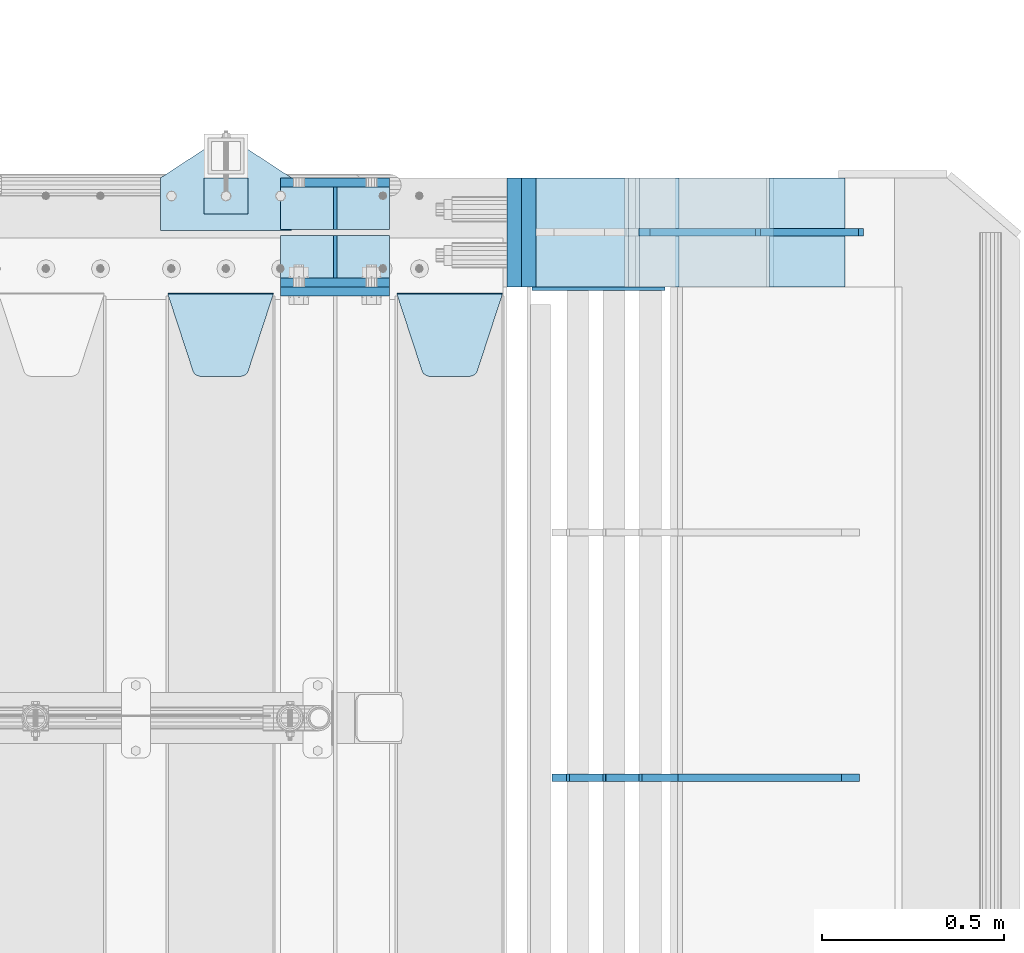
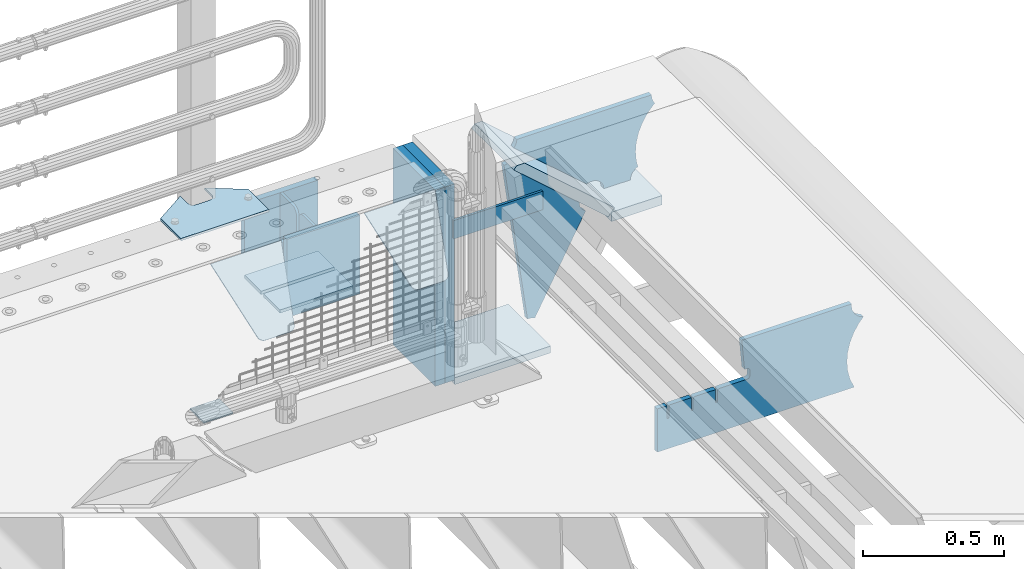
# One storey, part 231 of 247: 20 plates.
"""IFC2X3 building model written with IfcOpenShell, lengths in millimetres."""

from ifc_helpers import new_model, si_unit, frame, origin_with_axes, place, context, subcontext, project, spatial, faceted_brep, material, type_object, element, save


model = new_model("IFC2X3")

# Units and contexts
model_context = context("Model", 3, precision=1e-05, world=origin_with_axes())
body_context = subcontext(model_context, "Body", "Model", "MODEL_VIEW")
ifc_project = project(units=[si_unit("LENGTHUNIT", "METRE", prefix="MILLI"), si_unit("AREAUNIT", "SQUARE_METRE"), si_unit("VOLUMEUNIT", "CUBIC_METRE"), si_unit("MASSUNIT", "GRAM", prefix="KILO"), si_unit("TIMEUNIT", "SECOND"), si_unit("PLANEANGLEUNIT", "RADIAN"), si_unit("SOLIDANGLEUNIT", "STERADIAN"), si_unit("THERMODYNAMICTEMPERATUREUNIT", "DEGREE_CELSIUS"), si_unit("LUMINOUSINTENSITYUNIT", "LUMEN")], contexts=[model_context])

# Site, building, storey
site_placement = place(None, origin_with_axes())
site = spatial("IfcSite", under=ifc_project, at=site_placement, CompositionType="ELEMENT")
building_placement = place(site_placement, origin_with_axes())
building = spatial("IfcBuilding", under=site, at=building_placement, Name="Standard", CompositionType="ELEMENT")
storey_placement = place(building_placement, origin_with_axes())
storey = spatial("IfcBuildingStorey", under=building, at=storey_placement, Name="Undefined", CompositionType="ELEMENT", Elevation=0.0)

# Plates
ifc_material_1 = material(Name="STEEL/S355N")
plate_type_1 = type_object("IfcPlateType", PredefinedType="NOTDEFINED")
for number, where, z_axis, x_axis in (
    (1, (16195.0, 9137.49999999999, -339.999999999993), (0.0, 0.0, 1.0), (1.0, 0.0, 0.0)),
    (2, (16195.0, 8862.49999999999, -339.999999999993), (0.0, 0.0, 1.0), (1.0, 0.0, 0.0)),
):
    element("IfcPlate", number, at=place(storey_placement, frame(where, z_axis=z_axis, x_axis=x_axis)), inside=storey, type_object=plate_type_1, material=ifc_material_1, context=body_context, shape_type="Brep", body=[
        faceted_brep([(0.0, -12.5, 0.0), (0.0, -12.5, 310.0), (0.0, 12.5, 310.0), (0.0, 12.5, 0.0), (300.0, -12.5, 310.0), (300.0, 12.5, 310.0), (300.0, -12.5, 0.0), (300.0, 12.5, 0.0)], [[[0, 1, 2, 3]], [[1, 4, 5, 2]], [[4, 6, 7, 5]], [[6, 0, 3, 7]], [[5, 7, 3, 2]], [[6, 4, 1, 0]]]),
    ])
plate_1_placement = place(storey_placement, frame((16195.0, 8837.5, -340.000000000044), z_axis=(0.0, 0.0, 1.0), x_axis=(1.0, 0.0, 0.0)))
element("IfcPlate", 3, at=plate_1_placement, inside=storey, type_object=plate_type_1, material=ifc_material_1, context=body_context, shape_type="Brep", body=[
    faceted_brep([(0.0, -12.5, 0.0), (0.0, -12.5, 340.0), (0.0, 12.5, 340.0), (0.0, 12.5, 0.0), (300.0, -12.5, 340.0), (300.0, 12.5, 340.0), (300.0, -12.5, 0.0), (300.0, 12.5, 0.0)], [[[0, 1, 2, 3]], [[1, 4, 5, 2]], [[4, 6, 7, 5]], [[6, 0, 3, 7]], [[5, 7, 3, 2]], [[6, 4, 1, 0]]]),
])
plate_type_2 = type_object("IfcPlateType", PredefinedType="NOTDEFINED")
for number, where, z_axis, x_axis in (
    (4, (16195.0, 8991.99999999999, -342.999999999993), (0.0, -0.999999999999548, -9.5100000000016e-07), (1.0, 0.0, 0.0)),
    (5, (16195.0, 9007.99999999999, -342.999999999993), (0.0, 1.0, 0.0), (1.0, 0.0, 0.0)),
):
    element("IfcPlate", number, at=place(storey_placement, frame(where, z_axis=z_axis, x_axis=x_axis)), inside=storey, type_object=plate_type_2, material=ifc_material_1, context=body_context, shape_type="Brep", body=[
        faceted_brep([(0.0, -7.0, 0.0), (0.0, -7.0, 117.0), (0.0, 7.0, 117.0), (0.0, 7.0, 0.0), (300.0, -7.0, 117.0), (300.0, 7.0, 117.0), (300.0, -7.0, 0.0), (300.0, 7.0, 0.0)], [[[0, 1, 2, 3]], [[1, 4, 5, 2]], [[4, 6, 7, 5]], [[6, 0, 3, 7]], [[5, 7, 3, 2]], [[6, 4, 1, 0]]]),
    ])
plate_type_3 = type_object("IfcPlateType", PredefinedType="NOTDEFINED")
for number, where, z_axis, x_axis in (
    (6, (16345.0, 9007.99999999999, -29.999999999993), (0.0, 0.0, -1.0), (0.0, 1.0, 0.0)),
    (7, (16345.0, 8991.99999999999, -29.999999999993), (0.0, 0.0, -1.0), (0.0, -0.999999999999548, -9.5100000000016e-07)),
):
    element("IfcPlate", number, at=place(storey_placement, frame(where, z_axis=z_axis, x_axis=x_axis)), inside=storey, type_object=plate_type_3, material=ifc_material_1, context=body_context, shape_type="Brep", body=[
        faceted_brep([(0.0, -5.0, 30.0), (0.0, -5.0, 306.0), (0.0, 5.0, 306.0), (0.0, 5.0, 30.0), (117.0, -5.0, 306.0), (117.0, 5.0, 306.0), (117.0, -5.0, 0.0), (117.0, 5.0, 0.0), (30.0, -5.0, 0.0), (30.0, 5.0, 0.0), (24.7905546699922, -5.0, 0.455767409633758), (24.7905546699922, 5.0, 0.455767409633758), (19.73939570023, -5.0, 1.80922137642275), (19.73939570023, 5.0, 1.80922137642275), (15.0, -5.0, 4.01923788646684), (15.0, 5.0, 4.01923788646684), (10.716371709404, -5.0, 7.01866670643066), (10.716371709404, 5.0, 7.01866670643066), (7.01866670643085, -5.0, 10.7163717094038), (7.01866670643085, 5.0, 10.7163717094038), (4.01923788646673, -5.0, 15.0), (4.01923788646673, 5.0, 15.0), (1.80922137642256, -5.0, 19.7393957002299), (1.80922137642256, 5.0, 19.7393957002299), (0.455767409633609, -5.0, 24.7905546699921), (0.455767409633609, 5.0, 24.7905546699921)], [[[0, 1, 2, 3]], [[1, 4, 5, 2]], [[4, 6, 7, 5]], [[6, 8, 9, 7]], [[8, 10, 11, 9]], [[10, 12, 13, 11]], [[12, 14, 15, 13]], [[14, 16, 17, 15]], [[16, 18, 19, 17]], [[18, 20, 21, 19]], [[20, 22, 23, 21]], [[22, 24, 25, 23]], [[24, 0, 3, 25]], [[5, 7, 9, 11, 13, 15, 17, 19, 21, 23, 25, 3, 2]], [[24, 22, 20, 18, 16, 14, 12, 10, 8, 6, 4, 1, 0]]]),
    ])
plate_type_4 = type_object("IfcPlateType", PredefinedType="NOTDEFINED")
plate_2_placement = place(storey_placement, frame((16515.0, 8831.76776695594, -1.767766952965), z_axis=(0.0, -0.707106781186548, -0.707106781186547), x_axis=(1.0, 0.0, 0.0)))
element("IfcPlate", 8, at=plate_2_placement, inside=storey, type_object=plate_type_4, material=ifc_material_1, context=body_context, shape_type="Brep", body=[
    faceted_brep([(0.0, -2.49999999999909, 0.0), (69.345504679477, -2.5, 300.17173142483), (69.345504679477, 2.50000000000091, 300.171731424831), (0.0, 2.5, -9.09494701772928e-13), (70.9274061199576, -2.5, 304.897442415399), (70.9274061199576, 2.50000000000091, 304.8974424154), (73.3818627772307, -2.49999999999909, 309.234538108527), (73.3818627772307, 2.5, 309.234538108526), (76.6187032999551, -2.5, 313.023683126102), (76.6187032999551, 2.50000000000091, 313.023683126102), (80.5190132704993, -2.49999999999909, 316.125672595371), (80.5190132704993, 2.50000000000091, 316.125672595372), (84.9395038596849, -2.49999999999909, 318.426546230476), (84.9395038596849, 2.5, 318.426546230475), (89.7177759439219, -2.5, 319.841774983274), (89.7177759439219, 2.50000000000091, 319.841774983275), (94.678286292652, -2.5, 320.319366455077), (94.678286292652, 2.50000000000091, 320.319366455077), (195.321713707348, -2.5, 320.319366455077), (195.321713707348, 2.50000000000091, 320.319366455077), (200.282224056078, -2.5, 319.841774983274), (200.282224056078, 2.50000000000091, 319.841774983275), (205.060496140315, -2.5, 318.426546230475), (205.060496140315, 2.5, 318.426546230474), (209.480986729501, -2.49999999999818, 316.12567259537), (209.480986729501, 2.50000000000091, 316.12567259537), (213.381296700045, -2.5, 313.023683126101), (213.381296700045, 2.50000000000091, 313.023683126101), (216.618137222769, -2.5, 309.234538108525), (216.618137222769, 2.5, 309.234538108525), (219.072593880042, -2.49999999999909, 304.897442415398), (219.072593880042, 2.5, 304.897442415398), (220.654495320523, -2.5, 300.17173142483), (220.654495320523, 2.50000000000091, 300.171731424831), (290.0, -2.49999999999909, 0.0), (290.0, 2.5, -9.09494701772928e-13)], [[[0, 1, 2, 3]], [[1, 4, 5, 2]], [[4, 6, 7, 5]], [[6, 8, 9, 7]], [[8, 10, 11, 9]], [[10, 12, 13, 11]], [[12, 14, 15, 13]], [[14, 16, 17, 15]], [[16, 18, 19, 17]], [[18, 20, 21, 19]], [[20, 22, 23, 21]], [[22, 24, 25, 23]], [[24, 26, 27, 25]], [[26, 28, 29, 27]], [[28, 30, 31, 29]], [[30, 32, 33, 31]], [[32, 34, 35, 33]], [[34, 0, 3, 35]], [[5, 7, 9, 11, 13, 15, 17, 19, 21, 23, 25, 27, 29, 31, 33, 35, 3, 2]], [[34, 32, 30, 28, 26, 24, 22, 20, 18, 16, 14, 12, 10, 8, 6, 4, 1, 0]]]),
])
plate_3_placement = place(storey_placement, frame((15885.0, 8831.76776695594, -1.767766952965), z_axis=(0.0, -0.707106781186548, -0.707106781186547), x_axis=(1.0, 0.0, 0.0)))
element("IfcPlate", 9, at=plate_3_placement, inside=storey, type_object=plate_type_4, material=ifc_material_1, context=body_context, shape_type="Brep", body=[
    faceted_brep([(0.0, -2.49999999999909, 0.0), (69.345504679477, -2.5, 300.17173142483), (69.345504679477, 2.50000000000091, 300.171731424831), (0.0, 2.5, -9.09494701772928e-13), (70.9274061199576, -2.5, 304.897442415399), (70.9274061199576, 2.50000000000091, 304.8974424154), (73.3818627772307, -2.49999999999909, 309.234538108527), (73.3818627772307, 2.5, 309.234538108526), (76.6187032999551, -2.5, 313.023683126102), (76.6187032999551, 2.50000000000091, 313.023683126102), (80.5190132704993, -2.49999999999909, 316.125672595371), (80.5190132704993, 2.50000000000091, 316.125672595372), (84.9395038596849, -2.49999999999909, 318.426546230476), (84.9395038596849, 2.5, 318.426546230475), (89.7177759439219, -2.5, 319.841774983274), (89.7177759439219, 2.50000000000091, 319.841774983275), (94.678286292652, -2.5, 320.319366455077), (94.678286292652, 2.50000000000091, 320.319366455077), (195.321713707348, -2.5, 320.319366455077), (195.321713707348, 2.50000000000091, 320.319366455077), (200.282224056078, -2.5, 319.841774983274), (200.282224056078, 2.50000000000091, 319.841774983275), (205.060496140315, -2.5, 318.426546230475), (205.060496140315, 2.5, 318.426546230474), (209.480986729501, -2.49999999999818, 316.12567259537), (209.480986729501, 2.50000000000091, 316.12567259537), (213.381296700045, -2.5, 313.023683126101), (213.381296700045, 2.50000000000091, 313.023683126101), (216.618137222769, -2.5, 309.234538108525), (216.618137222769, 2.5, 309.234538108525), (219.072593880042, -2.49999999999909, 304.897442415398), (219.072593880042, 2.5, 304.897442415398), (220.654495320523, -2.5, 300.17173142483), (220.654495320523, 2.50000000000091, 300.171731424831), (290.0, -2.49999999999909, 0.0), (290.0, 2.5, -9.09494701772928e-13)], [[[0, 1, 2, 3]], [[1, 4, 5, 2]], [[4, 6, 7, 5]], [[6, 8, 9, 7]], [[8, 10, 11, 9]], [[10, 12, 13, 11]], [[12, 14, 15, 13]], [[14, 16, 17, 15]], [[16, 18, 19, 17]], [[18, 20, 21, 19]], [[20, 22, 23, 21]], [[22, 24, 25, 23]], [[24, 26, 27, 25]], [[26, 28, 29, 27]], [[28, 30, 31, 29]], [[30, 32, 33, 31]], [[32, 34, 35, 33]], [[34, 0, 3, 35]], [[5, 7, 9, 11, 13, 15, 17, 19, 21, 23, 25, 27, 29, 31, 33, 35, 3, 2]], [[34, 32, 30, 28, 26, 24, 22, 20, 18, 16, 14, 12, 10, 8, 6, 4, 1, 0]]]),
])
ifc_material_2 = material()
plate_type_5 = type_object("IfcPlateType", PredefinedType="NOTDEFINED")
plate_4_placement = place(storey_placement, frame((16837.0, 9150.0, -870.0), z_axis=(0.0, 0.0, 1.0), x_axis=(0.0, -0.999999999999548, -9.5100000000016e-07)))
element("IfcPlate", 10, at=plate_4_placement, inside=storey, type_object=plate_type_5, material=ifc_material_2, context=body_context, shape_type="Brep", body=[
    faceted_brep([(0.0, -20.0, 0.0), (0.0, -20.0, 850.0), (0.0, 20.0, 850.0), (0.0, 20.0, 0.0), (300.0, -20.0, 850.0), (300.0, 20.0, 850.0), (300.0, -20.0, -1.81898940354586e-12), (300.0, 20.0, -1.81898940354586e-12)], [[[0, 1, 2, 3]], [[1, 4, 5, 2]], [[4, 6, 7, 5]], [[6, 0, 3, 7]], [[5, 7, 3, 2]], [[6, 4, 1, 0]]]),
])
plate_5_placement = place(storey_placement, frame((17538.9988298898, 9149.9999999992, -367.999999999302), z_axis=(-0.752989422949573, 0.0, 0.658032619955933), x_axis=(0.0, -0.999999999999548, -9.5100000000016e-07)))
element("IfcPlate", 11, at=plate_5_placement, inside=storey, type_object=plate_type_5, material=ifc_material_1, context=body_context, shape_type="Brep", body=[
    faceted_brep([(-8.10757683211705e-10, 19.9999999999982, 490.766265601622), (4.54747350886464e-13, -0.303811250943909, 513.999999999998), (300.0, -0.303811250943909, 513.999999999998), (300.0, 19.9999999999982, 490.766265601622), (300.0, -20.0, -1.81898940354586e-12), (300.0, -20.0000000000018, 514.0), (4.54747350886464e-13, -20.0000000000018, 514.0), (0.0, -20.0, 0.0), (0.0, 20.0, 0.0), (300.0, 20.0, -1.81898940354586e-12)], [[[0, 1, 2, 3]], [[4, 5, 6, 7]], [[4, 7, 8, 9]], [[9, 8, 0, 3]], [[5, 4, 9, 3, 2]], [[6, 5, 2, 1]], [[8, 7, 6, 1, 0]]]),
])
plate_6_placement = place(storey_placement, frame((16876.9988298906, 9150.0, -870.000000000003), z_axis=(0.0, 0.0, 1.0), x_axis=(0.0, -0.999999999999548, -9.5100000000016e-07)))
element("IfcPlate", 12, at=plate_6_placement, inside=storey, type_object=plate_type_5, material=ifc_material_2, context=body_context, shape_type="Brep", body=[
    faceted_brep([(0.0, -20.0, 0.0), (0.0, -20.0, 850.0), (0.0, 20.0, 850.0), (0.0, 20.0, 0.0), (300.0, -20.0, 850.0), (300.0, 20.0, 850.0), (300.0, -20.0, -1.81898940354586e-12), (300.0, 20.0, -1.81898940354586e-12)], [[[0, 1, 2, 3]], [[1, 4, 5, 2]], [[4, 6, 7, 5]], [[6, 0, 3, 7]], [[5, 7, 3, 2]], [[6, 4, 1, 0]]]),
])
ifc_material_3 = material(Name="STEEL/S355J2")
plate_type_6 = type_object("IfcPlateType", PredefinedType="NOTDEFINED")
plate_7_placement = place(storey_placement, frame((15865.0, 9005.0, 5.00000000004911), z_axis=(0.0, 1.0, 0.0), x_axis=(1.0, 0.0, 0.0)))
element("IfcPlate", 13, at=plate_7_placement, inside=storey, type_object=plate_type_6, material=ifc_material_3, context=body_context, shape_type="Brep", body=[
    faceted_brep([(9.04219632502645e-09, -5.00000000143385, -2.89173840428703e-09), (2.31396552408114e-06, -5.0, 145.0), (2.31396552408114e-06, 5.0, 145.0), (7.66340235713869e-09, 4.99999999856618, -2.89173840428703e-09), (130.0, -5.0, 230.0), (130.0, 5.0, 230.0), (130.0, -5.0, 180.0), (130.0, 5.0, 180.0), (130.48036798992, -5.0, 175.122741949597), (130.48036798992, 5.0, 175.122741949597), (131.903011687218, -5.0, 170.432914190873), (131.903011687218, 5.0, 170.432914190873), (134.213259692437, -5.0, 166.11074417451), (134.213259692437, 5.0, 166.11074417451), (137.322330470337, -5.0, 162.322330470337), (137.322330470337, 5.0, 162.322330470337), (141.11074417451, -5.0, 159.213259692437), (141.11074417451, 5.0, 159.213259692437), (145.432914190873, -5.0, 156.903011687218), (145.432914190873, 5.0, 156.903011687218), (150.122741949597, -5.0, 155.48036798992), (150.122741949597, 5.0, 155.48036798992), (155.0, -5.0, 155.0), (155.0, 5.0, 155.0), (205.0, -5.0, 155.0), (205.0, 5.0, 155.0), (209.877258050403, -5.0, 155.48036798992), (209.877258050403, 5.0, 155.48036798992), (214.567085809127, -5.0, 156.903011687218), (214.567085809127, 5.0, 156.903011687218), (218.88925582549, -5.0, 159.213259692437), (218.88925582549, 5.0, 159.213259692437), (222.677669529663, -5.0, 162.322330470337), (222.677669529663, 5.0, 162.322330470337), (225.786740307563, -5.0, 166.11074417451), (225.786740307563, 5.0, 166.11074417451), (228.096988312782, -5.0, 170.432914190873), (228.096988312782, 5.0, 170.432914190873), (229.51963201008, -5.0, 175.122741949597), (229.51963201008, 5.0, 175.122741949597), (230.0, -5.0, 180.0), (230.0, 5.0, 180.0), (230.0, -5.0, 230.0), (230.0, 5.0, 230.0), (360.0, -5.0, 145.0), (360.0, 5.0, 145.0), (360.0, -5.0, -7.27595761418343e-12), (360.0, 5.0, -7.27595761418343e-12)], [[[0, 1, 2, 3]], [[1, 4, 5, 2]], [[4, 6, 7, 5]], [[6, 8, 9, 7]], [[8, 10, 11, 9]], [[10, 12, 13, 11]], [[12, 14, 15, 13]], [[14, 16, 17, 15]], [[16, 18, 19, 17]], [[18, 20, 21, 19]], [[20, 22, 23, 21]], [[22, 24, 25, 23]], [[24, 26, 27, 25]], [[26, 28, 29, 27]], [[28, 30, 31, 29]], [[30, 32, 33, 31]], [[32, 34, 35, 33]], [[34, 36, 37, 35]], [[36, 38, 39, 37]], [[38, 40, 41, 39]], [[40, 42, 43, 41]], [[42, 44, 45, 43]], [[44, 46, 47, 45]], [[46, 0, 3, 47]], [[5, 7, 9, 11, 13, 15, 17, 19, 21, 23, 25, 27, 29, 31, 33, 35, 37, 39, 41, 43, 45, 47, 3, 2]], [[46, 44, 42, 40, 38, 36, 34, 32, 30, 28, 26, 24, 22, 20, 18, 16, 14, 12, 10, 8, 6, 4, 1, 0]]]),
])
plate_type_7 = type_object("IfcPlateType", PredefinedType="NOTDEFINED")
plate_8_placement = place(storey_placement, frame((15985.0000000001, 9050.00000000021, -857.500000000002), z_axis=(0.0, 1.0, 0.0), x_axis=(1.0, 0.0, 0.0)))
element("IfcPlate", 14, at=plate_8_placement, inside=storey, type_object=plate_type_7, material=ifc_material_3, context=body_context, shape_type="Brep", body=[
    faceted_brep([(0.0, -2.49999999999909, 0.0), (0.0, -2.5, 100.0), (0.0, 2.5, 100.0), (0.0, 2.5, -9.09494701772928e-13), (120.0, -2.5, 100.0), (120.0, 2.5, 100.0), (120.0, -2.5, 0.0), (120.0, 2.5, 0.0)], [[[0, 1, 2, 3]], [[1, 4, 5, 2]], [[4, 6, 7, 5]], [[6, 0, 3, 7]], [[5, 7, 3, 2]], [[6, 4, 1, 0]]]),
])
plate_type_8 = type_object("IfcPlateType", PredefinedType="NOTDEFINED")
plate_9_placement = place(storey_placement, frame((17782.9182339676, 7499.99928283691, -374.002067436516), z_axis=(0.0, 0.0, 1.0), x_axis=(-1.0, 0.0, 0.0)))
element("IfcPlate", 15, at=plate_9_placement, inside=storey, type_object=plate_type_8, material=ifc_material_1, context=body_context, shape_type="Brep", body=[
    faceted_brep([(801.919404066546, -10.0, 188.0), (801.919404066546, 10.0, 188.0), (801.919404066546, 10.0, 132.002067436952), (801.919404066546, -10.0, 132.002067436952), (793.919404066546, 10.0, 132.002067436952), (793.919404066546, -10.0, 132.002067436952), (793.919404066546, 10.0, 180.002067436952), (793.919404066546, -10.0, 180.002067436952), (793.527856196906, 10.0, 182.474203391951), (793.527856196906, -10.0, 182.474203391951), (792.391540021545, 10.0, 184.704349455291), (792.391540021545, -10.0, 184.704349455291), (790.621686084887, 10.0, 186.474203391951), (790.621686084887, -10.0, 186.474203391951), (788.391540021545, 10.0, 187.610519567313), (788.391540021545, -10.0, 187.610519567313), (785.919404066546, -10.0, 188.002067436952), (785.919404066546, 10.0, 188.0), (841.0, -10.0, 188.0), (841.0, -10.0, 0.0), (841.0, 10.0, 0.0), (841.0, 10.0, 188.0), (33.3619566736015, -10.0, 0.0), (33.3619566736015, 10.0, 0.0), (36.2350612208174, -10.0, 4.68848050267013), (36.2350612208174, 10.0, 4.68848050267013), (51.4877592159428, -10.0, 41.5117508652784), (51.4877592159428, 10.0, 41.5117508652784), (60.792242588137, -10.0, 80.2677133162964), (60.792242588137, 10.0, 80.2677133162964), (63.9194040769726, -10.0, 120.002067436515), (63.9194040769726, 10.0, 120.002067436515), (60.792242588137, -10.0, 159.736421556734), (60.792242588137, 10.0, 159.736421556734), (51.4877592159428, -10.0, 198.492384007752), (51.4877592159428, 10.0, 198.492384007752), (36.2350612208174, -10.0, 235.31565437036), (36.2350612208174, 10.0, 235.31565437036), (15.4097206482074, -10.0, 269.299521518803), (15.4097206482074, 10.0, 269.299521518803), (-3.35474438098754, -10.0, 291.269887256574), (-3.35474438098754, 10.0, 291.269887256574), (-2.36881039375294, -10.0, 291.426043859339), (-2.36881039375294, 10.0, 291.426043859339), (17.1449676604716, -10.0, 301.368810393754), (17.1449676604716, 10.0, 301.368810393754), (32.6311896062471, -10.0, 316.855032339527), (32.6311896062471, 10.0, 316.855032339527), (42.573956140659, -10.0, 336.368810393754), (42.573956140659, 10.0, 336.368810393754), (46.0, -10.0, 358.0), (46.0, 10.0, 358.0), (45.0495205499137, -10.0, 364.001091067617), (45.0495205499137, 10.0, 364.001091067617), (495.040008544922, -10.0, 364.010009765625), (495.040008544922, 10.0, 364.010009765625), (483.600036621094, -10.0, 233.759994506836), (483.600036621094, 10.0, 233.759994506836), (472.0, -10.0, 233.759994506836), (472.0, 10.0, 233.759994506836), (468.909830056251, -10.0, 233.270559669787), (468.909830056251, 10.0, 233.270559669787), (466.122147477075, -10.0, 231.850164450585), (466.122147477075, 10.0, 231.850164450585), (463.909830056251, -10.0, 229.637847029761), (463.909830056251, 10.0, 229.637847029761), (462.489434837047, -10.0, 226.850164450585), (462.489434837047, 10.0, 226.850164450585), (462.0, -10.0, 223.759994506836), (462.0, 10.0, 223.759994506836), (462.0, -10.0, 198.0), (462.0, 10.0, 198.0), (462.489434837047, -10.0, 194.909830056251), (462.489434837047, 10.0, 194.909830056251), (463.909830056251, -10.0, 192.122147477075), (463.909830056251, 10.0, 192.122147477075), (466.122147477075, -10.0, 189.909830056251), (466.122147477075, 10.0, 189.909830056251), (468.909830056251, -10.0, 188.489434837048), (468.909830056251, 10.0, 188.489434837048), (472.0, -10.0, 188.0), (472.0, 10.0, 188.0), (585.919404066546, -10.0, 188.002067436952), (585.919404066546, 10.0, 188.0), (588.391540021545, -10.0, 187.610519567313), (588.391540021545, 10.0, 187.610519567313), (590.621686084887, -10.0, 186.474203391951), (590.621686084887, 10.0, 186.474203391951), (592.391540021545, -10.0, 184.704349455291), (592.391540021545, 10.0, 184.704349455291), (593.527856196906, -10.0, 182.474203391951), (593.527856196906, 10.0, 182.474203391951), (593.919404066546, -10.0, 180.002067436952), (593.919404066546, 10.0, 180.002067436952), (593.919404066546, -10.0, 132.002067436952), (593.919404066546, 10.0, 132.002067436952), (601.919404066546, -10.0, 132.002067436952), (601.919404066546, 10.0, 132.002067436952), (601.919404066546, -10.0, 188.0), (601.919404066546, 10.0, 188.0), (685.919404066546, -10.0, 188.002067436952), (685.919404066546, 10.0, 188.0), (688.391540021545, -10.0, 187.610519567313), (688.391540021545, 10.0, 187.610519567313), (690.621686084887, -10.0, 186.474203391951), (690.621686084887, 10.0, 186.474203391951), (692.391540021545, -10.0, 184.704349455291), (692.391540021545, 10.0, 184.704349455291), (693.527856196906, -10.0, 182.474203391951), (693.527856196906, 10.0, 182.474203391951), (693.919404066546, -10.0, 180.002067436952), (693.919404066546, 10.0, 180.002067436952), (693.919404066546, -10.0, 132.002067436952), (693.919404066546, 10.0, 132.002067436952), (701.919404066546, -10.0, 132.002067436952), (701.919404066546, 10.0, 132.002067436952), (701.919404066546, -10.0, 188.0), (701.919404066546, 10.0, 188.0)], [[[0, 1, 2, 3]], [[3, 2, 4, 5]], [[5, 4, 6, 7]], [[7, 6, 8, 9]], [[9, 8, 10, 11]], [[11, 10, 12, 13]], [[13, 12, 14, 15]], [[16, 15, 14, 17]], [[18, 19, 20, 21]], [[20, 19, 22, 23]], [[22, 24, 25, 23]], [[26, 27, 25, 24]], [[28, 29, 27, 26]], [[30, 31, 29, 28]], [[32, 33, 31, 30]], [[34, 35, 33, 32]], [[36, 37, 35, 34]], [[38, 39, 37, 36]], [[39, 38, 40, 41]], [[40, 42, 43, 41]], [[44, 45, 43, 42]], [[46, 47, 45, 44]], [[48, 49, 47, 46]], [[50, 51, 49, 48]], [[52, 53, 51, 50]], [[54, 55, 53, 52]], [[54, 56, 57, 55]], [[56, 58, 59, 57]], [[58, 60, 61, 59]], [[60, 62, 63, 61]], [[62, 64, 65, 63]], [[64, 66, 67, 65]], [[66, 68, 69, 67]], [[68, 70, 71, 69]], [[70, 72, 73, 71]], [[72, 74, 75, 73]], [[74, 76, 77, 75]], [[76, 78, 79, 77]], [[78, 80, 81, 79]], [[81, 80, 82, 83]], [[82, 84, 85, 83]], [[86, 87, 85, 84]], [[88, 89, 87, 86]], [[90, 91, 89, 88]], [[92, 93, 91, 90]], [[94, 95, 93, 92]], [[96, 97, 95, 94]], [[98, 99, 97, 96]], [[99, 98, 100, 101]], [[100, 102, 103, 101]], [[104, 105, 103, 102]], [[106, 107, 105, 104]], [[108, 109, 107, 106]], [[110, 111, 109, 108]], [[112, 113, 111, 110]], [[114, 115, 113, 112]], [[116, 117, 115, 114]], [[117, 116, 16, 17]], [[12, 10, 8, 6, 4, 2, 1, 21, 20, 23, 25, 27, 29, 31, 33, 35, 37, 39, 41, 43, 45, 47, 49, 51, 53, 55, 57, 59, 61, 63, 65, 67, 69, 71, 73, 75, 77, 79, 81, 83, 85, 87, 89, 91, 93, 95, 97, 99, 101, 103, 105, 107, 109, 111, 113, 115, 117, 17, 14]], [[18, 21, 1, 0]], [[116, 114, 112, 110, 108, 106, 104, 102, 100, 98, 96, 94, 92, 90, 88, 86, 84, 82, 80, 78, 76, 74, 72, 70, 68, 66, 64, 62, 60, 58, 56, 54, 52, 50, 48, 46, 44, 42, 40, 38, 36, 34, 32, 30, 28, 26, 24, 22, 19, 18, 0, 3, 5, 7, 9, 11, 13, 15, 16]]]),
])
plate_type_9 = type_object("IfcPlateType", PredefinedType="NOTDEFINED")
plate_10_placement = place(storey_placement, frame((17538.9988298898, 8849.9999999992, -387.999999999302), z_axis=(1.0, 0.0, 0.0), x_axis=(0.0, 1.0, 0.0)))
element("IfcPlate", 16, at=plate_10_placement, inside=storey, type_object=plate_type_9, material=ifc_material_1, context=body_context, shape_type="Brep", body=[
    faceted_brep([(0.0, -20.0, 0.0), (3.31056071445346e-10, -20.0, 208.0), (3.31056071445346e-10, 20.0, 208.0), (0.0, 20.0, 0.0), (300.0, -20.0, 208.0), (300.0, 20.0, 208.0), (300.0, -20.0, -1.81898940354586e-12), (300.0, 20.0, -1.81898940354586e-12)], [[[0, 1, 2, 3]], [[1, 4, 5, 2]], [[4, 6, 7, 5]], [[6, 0, 3, 7]], [[5, 7, 3, 2]], [[6, 4, 1, 0]]]),
])
plate_type_10 = type_object("IfcPlateType", PredefinedType="NOTDEFINED")
plate_11_placement = place(storey_placement, frame((17853.9988298898, 8999.99999999936, -29.9999999993023), z_axis=(-0.000446694000102124, 0.0, -0.99999990023223), x_axis=(-0.99999990023223, 0.0, 0.000446694000103734)))
element("IfcPlate", 17, at=plate_11_placement, inside=storey, type_object=plate_type_10, material=ifc_material_1, context=body_context, shape_type="Brep", body=[
    faceted_brep([(125.007775472979, 10.0, 291.842314882029), (131.755016800053, 10.0, 263.793234614468), (131.755016800053, -10.0, 263.793234614468), (125.007775472979, -10.0, 291.842314882029), (134.899927074483, 10.0, 224.060281342732), (134.899927074483, -10.0, 224.060281342732), (131.79051499522, 10.0, 184.324534302446), (131.79051499522, -10.0, 184.324534302446), (122.503344607208, 10.0, 145.564419461128), (122.503344607208, -10.0, 145.564419461128), (107.267096867745, 10.0, 108.734339483615), (107.267096867745, -10.0, 108.734339483615), (86.4569387623887, 10.0, 74.741173170983), (86.4569387623887, -10.0, 74.741173170983), (60.5852854486511, 10.0, 44.4219450946983), (60.5852854486511, -10.0, 44.4219450946983), (56.2519855253086, 10.0, 40.7176084148895), (56.2519855253086, -10.0, 40.7176084148895), (136.409234539125, -10.0, 297.721677540594), (147.386991180581, -10.0, 308.778803581017), (147.386991180581, 10.0, 308.778803581017), (136.409234539125, 10.0, 297.721677540594), (154.428166132755, -10.0, 322.678193223937), (154.428166132755, 10.0, 322.678193223937), (156.849001662977, -10.0, 338.070097995228), (156.849001662977, 10.0, 338.070097995228), (264.849004013293, -10.0, 338.118348049693), (264.849004013293, 10.0, 338.118348049693), (267.62876711955, -10.0, 321.701412969031), (267.62876711955, 10.0, 321.701412969031), (275.645118712178, -10.0, 307.107546191754), (275.645118712178, 10.0, 307.107546191754), (288.009068357209, -10.0, 295.955165748785), (288.009068357209, 10.0, 295.955165748785), (303.349489447533, -10.0, 289.481038692482), (303.349489447533, 10.0, 289.481038692482), (319.965173216926, -10.0, 288.403127172445), (319.965173216926, 10.0, 288.403127172445), (336.013487920231, -10.0, 292.840968489265), (336.013487920231, 10.0, 292.840968489265), (335.869079589844, -10.0, 293.150054931641), (335.869079589844, 10.0, 293.150054931641), (633.937057436444, -10.0, 32.8861672876965), (633.937057436444, 10.0, 32.8861672876965), (628.672097726401, -10.0, 25.6357574923157), (628.672097726401, 10.0, 25.6357574923157), (624.785781531271, -10.0, 17.5620477266101), (624.785781531271, 10.0, 17.5620477266101), (622.402919050601, -10.0, 8.92432757904926), (622.402919050601, 10.0, 8.92432757904926), (621.600036621097, -10.0, -8.74678107720683e-10), (621.600036621097, 10.0, -8.74678107720683e-10), (70.0, -10.0, -9.84989867447439e-11), (70.0, 10.0, -9.84989867447439e-11), (67.7728137216618, -10.0, 17.5170123094482), (67.7728137216618, 10.0, 17.5170123094482), (61.2329794213983, -10.0, 33.9193489203215), (61.2329794213983, 10.0, 33.9193489203215)], [[[0, 1, 2, 3]], [[4, 5, 2, 1]], [[6, 7, 5, 4]], [[8, 9, 7, 6]], [[10, 11, 9, 8]], [[12, 13, 11, 10]], [[14, 15, 13, 12]], [[16, 17, 15, 14]], [[18, 19, 20, 21]], [[19, 22, 23, 20]], [[22, 24, 25, 23]], [[24, 26, 27, 25]], [[26, 28, 29, 27]], [[28, 30, 31, 29]], [[30, 32, 33, 31]], [[32, 34, 35, 33]], [[34, 36, 37, 35]], [[36, 38, 39, 37]], [[38, 40, 41, 39]], [[40, 42, 43, 41]], [[42, 44, 45, 43]], [[44, 46, 47, 45]], [[46, 48, 49, 47]], [[48, 50, 51, 49]], [[50, 52, 53, 51]], [[52, 54, 55, 53]], [[54, 56, 57, 55]], [[12, 10, 8, 6, 4, 1, 0, 21, 20, 23, 25, 27, 29, 31, 33, 35, 37, 39, 41, 43, 45, 47, 49, 51, 53, 55, 57, 16, 14]], [[18, 21, 0, 3]], [[56, 54, 52, 50, 48, 46, 44, 42, 40, 38, 36, 34, 32, 30, 28, 26, 24, 22, 19, 18, 3, 2, 5, 7, 9, 11, 13, 15, 17]], [[57, 56, 17, 16]]]),
])
plate_type_11 = type_object("IfcPlateType", PredefinedType="NOTDEFINED")
plate_12_placement = place(storey_placement, frame((17538.0025685034, 9000.000000001, -393.996688204407), z_axis=(-0.658066357015091, 0.0, -0.752959939017267), x_axis=(-0.752959939017266, 0.0, 0.658066357015093)))
element("IfcPlate", 18, at=plate_12_placement, inside=storey, type_object=plate_type_11, material=ifc_material_1, context=body_context, shape_type="Brep", body=[
    faceted_brep([(-11.3595226159596, -10.0, 48.6925173505915), (-112.015767301031, -10.0, 480.154833723631), (-112.015767301031, 10.0, 480.154833723631), (-11.3595226159596, 10.0, 48.6925173505915), (-104.567323293641, -10.0, 482.519601382541), (-104.567323293641, 10.0, 482.519601382541), (-97.5783311599971, -10.0, 486.016090073756), (-97.5783311599971, 10.0, 486.016090073756), (-91.2195220373815, -10.0, 490.558885551654), (-91.2195220373815, 10.0, 490.558885551654), (-85.646232588424, -10.0, 496.037013784004), (-85.646232588424, 10.0, 496.037013784004), (447.024482710494, -10.0, 32.8103372896385), (447.024482710494, 10.0, 32.8103372896385), (441.786973010396, -10.0, 25.5709623937291), (441.786973010396, 10.0, 25.5709623937291), (437.921644570128, -10.0, 17.5149526624118), (437.921644570128, 10.0, 17.5149526624118), (435.551940606496, -10.0, 8.89958500531793), (435.551940606496, 10.0, 8.89958500531793), (434.753540039063, -10.0, -5.16592990607023e-10), (434.753540039063, 10.0, -5.16592990607023e-10), (50.0, -10.0, 0.0), (50.0, 10.0, 0.0), (47.7668538974231, -10.0, 14.7759151575174), (47.7668538974231, 10.0, 14.7759151575174), (41.2668932502802, -10.0, 28.2319592212443), (41.2668932502802, 10.0, 28.2319592212443), (31.0807325300175, -10.0, 39.1661596968297), (31.0807325300175, 10.0, 39.1661596968297), (18.1182591411507, -10.0, 46.6018098971963), (18.1182591411507, 10.0, 46.6018098971963), (3.5373569608073, -10.0, 49.874714091733), (3.5373569608073, 10.0, 49.874714091733)], [[[0, 1, 2, 3]], [[1, 4, 5, 2]], [[4, 6, 7, 5]], [[6, 8, 9, 7]], [[8, 10, 11, 9]], [[10, 12, 13, 11]], [[12, 14, 15, 13]], [[14, 16, 17, 15]], [[16, 18, 19, 17]], [[18, 20, 21, 19]], [[20, 22, 23, 21]], [[22, 24, 25, 23]], [[24, 26, 27, 25]], [[26, 28, 29, 27]], [[28, 30, 31, 29]], [[30, 32, 33, 31]], [[32, 0, 3, 33]], [[5, 7, 9, 11, 13, 15, 17, 19, 21, 23, 25, 27, 29, 31, 33, 3, 2]], [[32, 30, 28, 26, 24, 22, 20, 18, 16, 14, 12, 10, 8, 6, 4, 1, 0]]]),
])
plate_type_12 = type_object("IfcPlateType", PredefinedType="NOTDEFINED")
plate_13_placement = place(storey_placement, frame((17289.9988298891, 9150.0, -875.000000003253), z_axis=(0.0, -0.999999999999548, -9.5100000000016e-07), x_axis=(-1.0, 0.0, 0.0)))
element("IfcPlate", 19, at=plate_13_placement, inside=storey, type_object=plate_type_12, material=ifc_material_1, context=body_context, shape_type="Brep", body=[
    faceted_brep([(0.0, -15.0, 0.0), (0.0, -15.0, 300.0), (0.0, 15.0, 300.0), (0.0, 15.0, 0.0), (393.0, -15.0, 300.0), (393.0, 15.0, 300.0), (393.0, -15.0, 1.50635059981141e-12), (393.0, 15.0, 1.50635059981141e-12)], [[[0, 1, 2, 3]], [[1, 4, 5, 2]], [[4, 6, 7, 5]], [[6, 0, 3, 7]], [[5, 7, 3, 2]], [[6, 4, 1, 0]]]),
])
plate_type_13 = type_object("IfcPlateType", PredefinedType="NOTDEFINED")
plate_14_placement = place(storey_placement, frame((17251.998829901, 8844.9999004229, -249.999999999564), z_axis=(-1.0, 0.0, 0.0), x_axis=(0.0, 0.0, 1.0)))
element("IfcPlate", 20, at=plate_14_placement, inside=storey, type_object=plate_type_13, material=ifc_material_1, context=body_context, shape_type="Brep", body=[
    faceted_brep([(9.04219632502645e-09, -5.00000000143385, -2.89173840428703e-09), (0.0, -5.0, 365.0), (0.0, 5.0, 365.0), (7.66340235713869e-09, 4.99999999856618, -2.89173840428703e-09), (80.0, -5.0, 365.0), (80.0, 5.0, 365.0), (80.0, -5.0, 0.0), (80.0, 5.0, 0.0)], [[[0, 1, 2, 3]], [[1, 4, 5, 2]], [[4, 6, 7, 5]], [[6, 0, 3, 7]], [[5, 7, 3, 2]], [[6, 4, 1, 0]]]),
])

save(model, "model.ifc")
